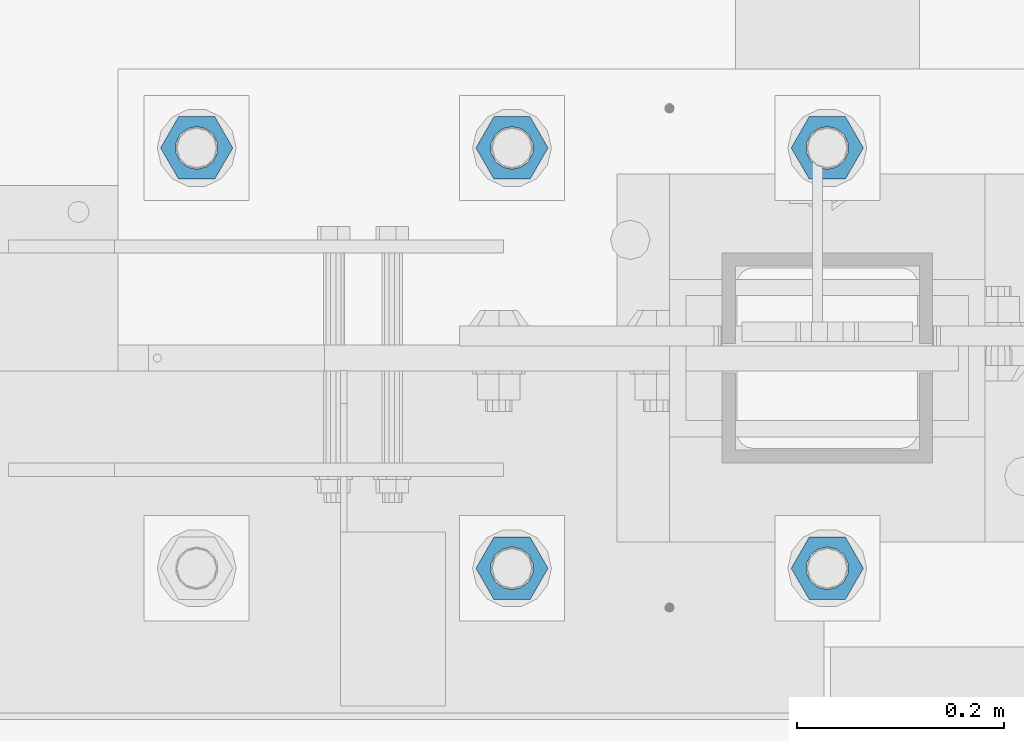
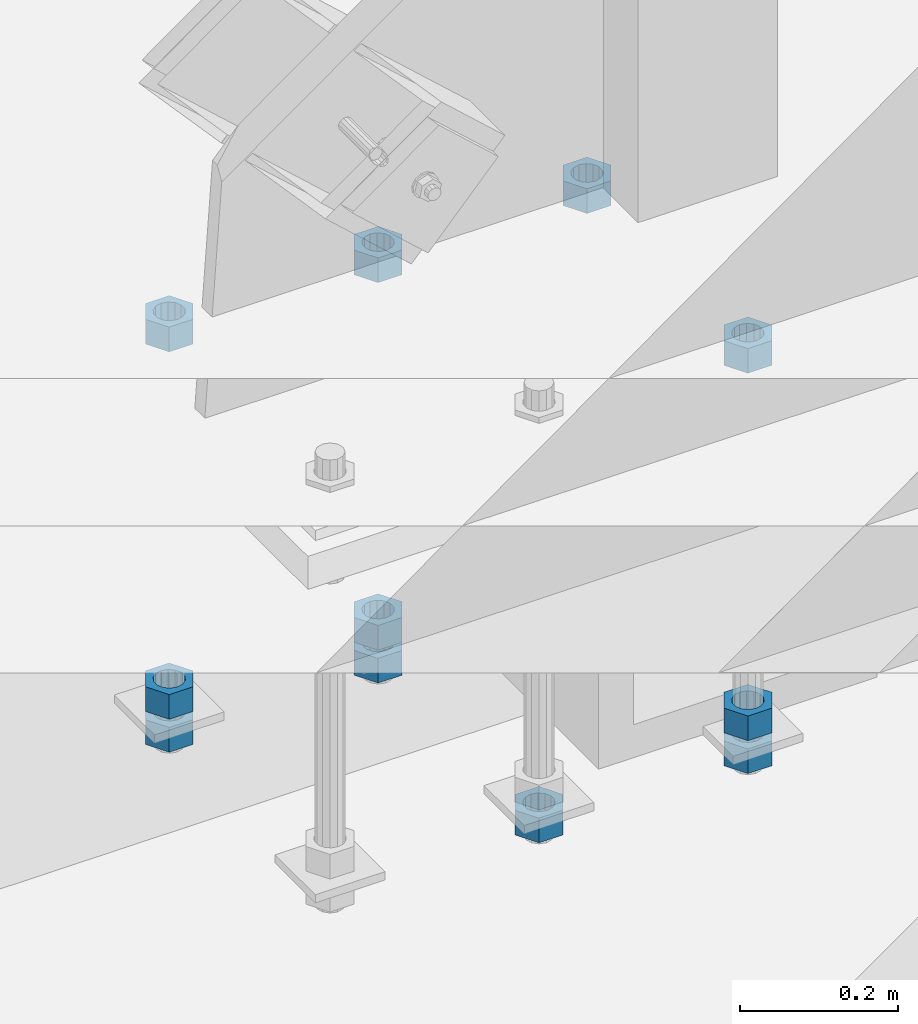
# One storey, part 982 of 1763: 11 columns, 1 element without a shape of its own.
"""IFC2X3 building model written with IfcOpenShell, lengths in millimetres."""

import ifcopenshell
import ifcopenshell.guid

model = None  # the IFC model being written
_history = None  # IfcOwnerHistory: only IFC2X3 demands one
_inside = {}  # id of a spatial element -> (the spatial element, [elements in it])
_under = {}  # id of a project, library or spatial element -> (it, [spatial elements below it])
_declared = {}  # id of a project -> (the project, [libraries it declares])
_typed = {}  # id of a type object -> (the type object, [elements of that type])
_made_of = {}  # id of a material, layer set ... -> (it, [elements and type objects made of it])


def new_model(schema):
    """Start an empty IFC model of exactly this schema.

    Asked for "IFC4X3", IfcOpenShell would pick the latest addendum, in which some entities
    have other attributes; the version numbers below select the first issue.
    IFC2X3 requires an IfcOwnerHistory on every rooted entity: one is made here for all.
    """
    global model, _history
    if schema == "IFC4X3":
        model = ifcopenshell.file(schema_version=(4, 3, 0, 0))
    else:
        model = ifcopenshell.file(schema=schema)
    _inside.clear()
    _under.clear()
    _declared.clear()
    _typed.clear()
    _made_of.clear()
    _history = None
    if model.schema == "IFC2X3":
        org = make("IfcOrganization", Name="unknown")
        user = make(
            "IfcPersonAndOrganization",
            ThePerson=make("IfcPerson", FamilyName="unknown"),
            TheOrganization=org,
        )
        app = make(
            "IfcApplication",
            ApplicationDeveloper=org,
            Version="unknown",
            ApplicationFullName="unknown",
            ApplicationIdentifier="unknown",
        )
        _history = make(
            "IfcOwnerHistory",
            OwningUser=user,
            OwningApplication=app,
            ChangeAction="ADDED",
            CreationDate=0,
        )
    return model


def make(cls, **values):
    """One entity of the class cls with the attributes given. An attribute that is None is left unset."""
    return model.create_entity(
        cls, **{name: value for name, value in values.items() if value is not None}
    )


def rooted(cls, **values):
    """An entity with a GlobalId (a new one), such as an element, a storey or a relation."""
    return make(cls, GlobalId=ifcopenshell.guid.new(), OwnerHistory=_history, **values)


def si_unit(unit_type, name, prefix=None):
    """IfcSIUnit, for example si_unit("LENGTHUNIT", "METRE", prefix="MILLI")."""
    return make("IfcSIUnit", UnitType=unit_type, Prefix=prefix, Name=name)


def assignment(units):
    """IfcUnitAssignment: the units of a project."""
    return None if units is None else make("IfcUnitAssignment", Units=units)


def point(xyz):
    """IfcCartesianPoint."""
    return None if xyz is None else make("IfcCartesianPoint", Coordinates=xyz)


def direction(xyz):
    """IfcDirection."""
    return None if xyz is None else make("IfcDirection", DirectionRatios=xyz)


def frame(location, z_axis=None, x_axis=None):
    """IfcAxis2Placement3D, a coordinate frame: its origin and axes. An axis left out is left unset."""
    return make(
        "IfcAxis2Placement3D",
        Location=point(location),
        Axis=direction(z_axis),
        RefDirection=direction(x_axis),
    )


def origin_with_axes():
    """The frame at (0, 0, 0) with the z axis (0, 0, 1) and the x axis (1, 0, 0) written out."""
    return frame((0.0, 0.0, 0.0), z_axis=(0.0, 0.0, 1.0), x_axis=(1.0, 0.0, 0.0))


def place(relative_to, where):
    """IfcLocalPlacement: puts the frame where relative to a parent placement (None: the world)."""
    return make(
        "IfcLocalPlacement", PlacementRelTo=relative_to, RelativePlacement=where
    )


def context(
    kind, dimensions, precision=None, world=None, true_north=None, identifier=None
):
    """IfcGeometricRepresentationContext, for example the 3D "Model" context."""
    return make(
        "IfcGeometricRepresentationContext",
        ContextIdentifier=identifier,
        ContextType=kind,
        CoordinateSpaceDimension=dimensions,
        Precision=precision,
        WorldCoordinateSystem=world,
        TrueNorth=true_north,
    )


def subcontext(parent, identifier, kind, view, scale=None):
    """IfcGeometricRepresentationSubContext, for example "Body" below "Model"."""
    return make(
        "IfcGeometricRepresentationSubContext",
        ContextIdentifier=identifier,
        ContextType=kind,
        ParentContext=parent,
        TargetScale=scale,
        TargetView=view,
    )


def project(units=None, contexts=None):
    """IfcProject with its units and contexts."""
    return rooted(
        "IfcProject",
        Name="project",
        RepresentationContexts=contexts,
        UnitsInContext=assignment(units),
    )


def spatial(cls, under=None, at=None, **own):
    """A site, building, storey or space (cls), placed at a placement, below another one or the project."""
    s = rooted(cls, ObjectPlacement=at, **own)
    if under is not None:
        _under.setdefault(under.id(), (under, []))[1].append(s)
    return s


def faces_of(points, faces, orient=None, outer=None):
    """IfcFace entities. A face is a list of loops; a loop is a list of indices into points, from 0.

    orient and outer hold one flag for each loop. By default every Orientation is true, the
    first loop of a face is its IfcFaceOuterBound and the others are IfcFaceBound.
    """
    made = []
    for i, loops in enumerate(faces):
        bounds = []
        for j, loop in enumerate(loops):
            is_outer = j == 0 if outer is None else outer[i][j]
            bounds.append(
                make(
                    "IfcFaceOuterBound" if is_outer else "IfcFaceBound",
                    Bound=make("IfcPolyLoop", Polygon=[points[k] for k in loop]),
                    Orientation=True if orient is None else orient[i][j],
                )
            )
        made.append(make("IfcFace", Bounds=bounds))
    return made


def faceted_brep(points, faces, orient=None, outer=None, voids=None):
    """IfcFacetedBrep: a solid bounded by flat faces; with voids (closed shells), ...WithVoids."""
    shared = [point(p) for p in points]
    hull = make("IfcClosedShell", CfsFaces=faces_of(shared, faces, orient, outer))
    if voids is None:
        return make("IfcFacetedBrep", Outer=hull)
    return make(
        "IfcFacetedBrepWithVoids",
        Outer=hull,
        Voids=[
            make(cls, CfsFaces=faces_of(shared, fs, o, b)) for cls, fs, o, b in voids
        ],
    )


def shape(context_of_items, identifier, shape_type, items):
    """IfcShapeRepresentation: the items that make up one representation, for example the "Body"."""
    return make(
        "IfcShapeRepresentation",
        ContextOfItems=context_of_items,
        RepresentationIdentifier=identifier,
        RepresentationType=shape_type,
        Items=items,
    )


def material(Name=None, Category=None):
    """IfcMaterial."""
    return make("IfcMaterial", Name=Name, Category=Category)


def made_of(thing, what):
    """Note that an element or type object is made of a material, layer set ...; save() writes the relation."""
    if what is not None:
        _made_of.setdefault(what.id(), (what, []))[1].append(thing)
    return thing


def type_object(cls, material=None, **own):
    """A type object (cls), such as IfcWallType, which elements share."""
    return made_of(rooted(cls, **own), material)


def element(
    cls,
    number,
    at=None,
    inside=None,
    cuts=None,
    type_object=None,
    material=None,
    context=None,
    identifier="Body",
    shape_type=None,
    held_by="IfcProductDefinitionShape",
    body=None,
    shapes=None,
    **own,
):
    """One element of the class cls, such as IfcWall. Its Tag is "e" and its number.

    at: its placement. inside: the storey or other place that contains it. cuts: it is an
    opening in that element (IfcRelVoidsElement). A single representation is given by context,
    identifier, shape_type and body (its items); several are given by shapes. held_by: the class
    of the entity that holds the representations. save() writes the other relations.
    """
    e = rooted(cls, Tag="e%d" % number, ObjectPlacement=at, **own)
    if body is not None:
        shapes = [shape(context, identifier, shape_type, body)]
    if shapes is not None:
        e.Representation = make(held_by, Representations=shapes)
    if inside is not None:
        _inside.setdefault(inside.id(), (inside, []))[1].append(e)
    if cuts is not None:
        rooted(
            "IfcRelVoidsElement", RelatingBuildingElement=cuts, RelatedOpeningElement=e
        )
    if type_object is not None:
        _typed.setdefault(type_object.id(), (type_object, []))[1].append(e)
    return made_of(e, material)


def aggregate(whole, parts):
    """IfcRelAggregates: a whole, such as a stair, and the parts it consists of."""
    return rooted("IfcRelAggregates", RelatingObject=whole, RelatedObjects=parts)


def save(model, path):
    """Write the relations noted so far, then the file.

    IfcRelAggregates (storeys below a building ...), IfcRelContainedInSpatialStructure (elements
    in a storey), IfcRelDefinesByType, IfcRelAssociatesMaterial and IfcRelDeclares: one each for
    every whole, place, type object, material and project.
    """
    for whole, parts in _under.values():
        aggregate(whole, parts)
    for where, things in _inside.values():
        rooted(
            "IfcRelContainedInSpatialStructure",
            RelatedElements=things,
            RelatingStructure=where,
        )
    for kind, things in _typed.values():
        rooted("IfcRelDefinesByType", RelatedObjects=things, RelatingType=kind)
    for what, things in _made_of.values():
        rooted("IfcRelAssociatesMaterial", RelatedObjects=things, RelatingMaterial=what)
    for by, libraries in _declared.values():
        rooted("IfcRelDeclares", RelatingContext=by, RelatedDefinitions=libraries)
    model.write(path)


model = new_model("IFC2X3")

# Units and contexts
model_context = context("Model", 3, precision=1e-05, world=origin_with_axes())
body_context = subcontext(model_context, "Body", "Model", "MODEL_VIEW")
ifc_project = project(units=[si_unit("LENGTHUNIT", "METRE", prefix="MILLI"), si_unit("AREAUNIT", "SQUARE_METRE"), si_unit("VOLUMEUNIT", "CUBIC_METRE"), si_unit("MASSUNIT", "GRAM", prefix="KILO"), si_unit("TIMEUNIT", "SECOND"), si_unit("PLANEANGLEUNIT", "RADIAN"), si_unit("SOLIDANGLEUNIT", "STERADIAN"), si_unit("THERMODYNAMICTEMPERATUREUNIT", "DEGREE_CELSIUS"), si_unit("LUMINOUSINTENSITYUNIT", "LUMEN")], contexts=[model_context])

# Site, building, storey
site_placement = place(None, origin_with_axes())
site = spatial("IfcSite", under=ifc_project, at=site_placement, CompositionType="ELEMENT")
building_placement = place(site_placement, origin_with_axes())
building = spatial("IfcBuilding", under=site, at=building_placement, Name="Undefined", CompositionType="ELEMENT")
storey_placement = place(building_placement, origin_with_axes())
storey = spatial("IfcBuildingStorey", under=building, at=storey_placement, Name="Undefined", CompositionType="ELEMENT", Elevation=0.0)

# Assembly, columns
assembly_placement = place(storey_placement, origin_with_axes())
assembly = element("IfcElementAssembly", 1, at=assembly_placement, inside=storey, Name="TEMPLATE", AssemblyPlace="NOTDEFINED", PredefinedType="RIGID_FRAME")
ifc_material = material(Name="STEEL/A563")
column_type = type_object("IfcColumnType", Name="1-1/2_HEAVY_HEX_NUT", PredefinedType="NOTDEFINED")
column_1_placement = place(assembly_placement, frame((-72795.8372736984, -13919.2, 4572.0), z_axis=(0.0, -1.0, 0.0), x_axis=(0.0, 0.0, -1.0)))
column_1 = element("IfcColumn", 2, at=column_1_placement, type_object=column_type, material=ifc_material, Name="NUT", ObjectType="1-1/2_HEAVY_HEX_NUT", context=body_context, shape_type="Brep", body=[
    faceted_brep([(0.0, -34.9199981689453, 0.0), (0.0, -17.4599990844727, -30.25), (38.1000000000004, -17.4599990844727, -30.25), (38.1000000000004, -34.9199981689453, 0.0), (0.0, 17.4599990844727, -30.25), (38.1000000000004, 17.4599990844727, -30.25), (0.0, 34.9199981689453, 0.0), (38.1000000000004, 34.9199981689453, 0.0), (0.0, 17.4599990844727, 30.25), (38.1000000000004, 17.4599990844727, 30.25), (0.0, -17.4599990844727, 30.25), (38.1000000000004, -17.4599990844727, 30.25), (0.0, 0.0, 20.6399993896484), (0.0, 8.95536011056538, 18.5959968835978), (38.1000000000004, 8.95536011056538, 18.5959968835978), (38.1000000000004, 0.0, 20.6399993896484), (0.0, 16.1370013209453, 12.8688291298167), (38.1000000000004, 16.1370013209453, 12.8688291298167), (0.0, 20.1225115123816, 4.59283194104137), (38.1000000000004, 20.1225115123816, 4.59283194104137), (0.0, 20.1225115123816, -4.59283194104319), (38.1000000000004, 20.1225115123816, -4.59283194104319), (0.0, 16.1370013209453, -12.8688291298167), (38.1000000000004, 16.1370013209453, -12.8688291298167), (0.0, 8.95536011056538, -18.5959968835978), (38.1000000000004, 8.95536011056538, -18.5959968835978), (0.0, 0.0, -20.6399993896484), (38.1000000000004, 0.0, -20.6399993896484), (0.0, -8.95536011056538, -18.5959968835978), (38.1000000000004, -8.95536011056538, -18.5959968835978), (0.0, -16.1370013209453, -12.8688291298167), (38.1000000000004, -16.1370013209453, -12.8688291298167), (0.0, -20.1225115123816, -4.59283194104137), (38.1000000000004, -20.1225115123816, -4.59283194104137), (0.0, -20.1225115123816, 4.59283194104319), (38.1000000000004, -20.1225115123816, 4.59283194104319), (0.0, -16.1370013209453, 12.8688291298167), (38.1000000000004, -16.1370013209453, 12.8688291298167), (0.0, -8.95536011056538, 18.5959968835978), (38.1000000000004, -8.95536011056538, 18.5959968835978)], [[[0, 1, 2, 3]], [[1, 4, 5, 2]], [[4, 6, 7, 5]], [[6, 8, 9, 7]], [[8, 10, 11, 9]], [[10, 0, 3, 11]], [[12, 13, 14, 15]], [[13, 16, 17, 14]], [[16, 18, 19, 17]], [[18, 20, 21, 19]], [[20, 22, 23, 21]], [[22, 24, 25, 23]], [[24, 26, 27, 25]], [[26, 28, 29, 27]], [[28, 30, 31, 29]], [[30, 32, 33, 31]], [[32, 34, 35, 33]], [[34, 36, 37, 35]], [[36, 38, 39, 37]], [[38, 12, 15, 39]], [[5, 7, 9, 11, 3, 2], [17, 19, 21, 23, 25, 27, 29, 31, 33, 35, 37, 39, 15, 14]], [[10, 8, 6, 4, 1, 0], [38, 36, 34, 32, 30, 28, 26, 24, 22, 20, 18, 16, 13, 12]]]),
])
column_2_placement = place(assembly_placement, frame((-72491.0372736984, -13919.2, 5189.5375), z_axis=(0.0, 1.0, 0.0), x_axis=(0.0, 0.0, -1.0)))
column_2 = element("IfcColumn", 3, at=column_2_placement, type_object=column_type, material=ifc_material, Name="NUT", ObjectType="1-1/2_HEAVY_HEX_NUT", context=body_context, shape_type="Brep", body=[
    faceted_brep([(0.0, -34.9199981689453, 0.0), (0.0, -17.4599990844727, -30.25), (38.1000000000004, -17.4599990844727, -30.25), (38.1000000000004, -34.9199981689453, 0.0), (0.0, 17.4599990844727, -30.25), (38.1000000000004, 17.4599990844727, -30.25), (0.0, 34.9199981689453, 0.0), (38.1000000000004, 34.9199981689453, 0.0), (0.0, 17.4599990844727, 30.25), (38.1000000000004, 17.4599990844727, 30.25), (0.0, -17.4599990844727, 30.25), (38.1000000000004, -17.4599990844727, 30.25), (0.0, 0.0, 20.6399993896484), (0.0, 8.95536011056538, 18.5959968835978), (38.1000000000004, 8.95536011056538, 18.5959968835978), (38.1000000000004, 0.0, 20.6399993896484), (0.0, 16.1370013209453, 12.8688291298167), (38.1000000000004, 16.1370013209453, 12.8688291298167), (0.0, 20.1225115123816, 4.59283194104137), (38.1000000000004, 20.1225115123816, 4.59283194104137), (0.0, 20.1225115123816, -4.59283194104319), (38.1000000000004, 20.1225115123816, -4.59283194104319), (0.0, 16.1370013209453, -12.8688291298167), (38.1000000000004, 16.1370013209453, -12.8688291298167), (0.0, 8.95536011056538, -18.5959968835978), (38.1000000000004, 8.95536011056538, -18.5959968835978), (0.0, 0.0, -20.6399993896484), (38.1000000000004, 0.0, -20.6399993896484), (0.0, -8.95536011056538, -18.5959968835978), (38.1000000000004, -8.95536011056538, -18.5959968835978), (0.0, -16.1370013209453, -12.8688291298167), (38.1000000000004, -16.1370013209453, -12.8688291298167), (0.0, -20.1225115123816, -4.59283194104137), (38.1000000000004, -20.1225115123816, -4.59283194104137), (0.0, -20.1225115123816, 4.59283194104319), (38.1000000000004, -20.1225115123816, 4.59283194104319), (0.0, -16.1370013209453, 12.8688291298167), (38.1000000000004, -16.1370013209453, 12.8688291298167), (0.0, -8.95536011056538, 18.5959968835978), (38.1000000000004, -8.95536011056538, 18.5959968835978)], [[[0, 1, 2, 3]], [[1, 4, 5, 2]], [[4, 6, 7, 5]], [[6, 8, 9, 7]], [[8, 10, 11, 9]], [[10, 0, 3, 11]], [[12, 13, 14, 15]], [[13, 16, 17, 14]], [[16, 18, 19, 17]], [[18, 20, 21, 19]], [[20, 22, 23, 21]], [[22, 24, 25, 23]], [[24, 26, 27, 25]], [[26, 28, 29, 27]], [[28, 30, 31, 29]], [[30, 32, 33, 31]], [[32, 34, 35, 33]], [[34, 36, 37, 35]], [[36, 38, 39, 37]], [[38, 12, 15, 39]], [[5, 7, 9, 11, 3, 2], [17, 19, 21, 23, 25, 27, 29, 31, 33, 35, 37, 39, 15, 14]], [[10, 8, 6, 4, 1, 0], [38, 36, 34, 32, 30, 28, 26, 24, 22, 20, 18, 16, 13, 12]]]),
])
column_3_placement = place(assembly_placement, frame((-72491.0372736984, -13919.2, 4622.8), z_axis=(0.0, 1.0, 0.0), x_axis=(0.0, 0.0, -1.0)))
column_3 = element("IfcColumn", 4, at=column_3_placement, type_object=column_type, material=ifc_material, Name="NUT", ObjectType="1-1/2_HEAVY_HEX_NUT", context=body_context, shape_type="Brep", body=[
    faceted_brep([(0.0, -34.9199981689453, 0.0), (0.0, -17.4599990844727, -30.25), (38.1000000000004, -17.4599990844727, -30.25), (38.1000000000004, -34.9199981689453, 0.0), (0.0, 17.4599990844727, -30.25), (38.1000000000004, 17.4599990844727, -30.25), (0.0, 34.9199981689453, 0.0), (38.1000000000004, 34.9199981689453, 0.0), (0.0, 17.4599990844727, 30.25), (38.1000000000004, 17.4599990844727, 30.25), (0.0, -17.4599990844727, 30.25), (38.1000000000004, -17.4599990844727, 30.25), (0.0, 0.0, 20.6399993896484), (0.0, 8.95536011056538, 18.5959968835978), (38.1000000000004, 8.95536011056538, 18.5959968835978), (38.1000000000004, 0.0, 20.6399993896484), (0.0, 16.1370013209453, 12.8688291298167), (38.1000000000004, 16.1370013209453, 12.8688291298167), (0.0, 20.1225115123816, 4.59283194104137), (38.1000000000004, 20.1225115123816, 4.59283194104137), (0.0, 20.1225115123816, -4.59283194104319), (38.1000000000004, 20.1225115123816, -4.59283194104319), (0.0, 16.1370013209453, -12.8688291298167), (38.1000000000004, 16.1370013209453, -12.8688291298167), (0.0, 8.95536011056538, -18.5959968835978), (38.1000000000004, 8.95536011056538, -18.5959968835978), (0.0, 0.0, -20.6399993896484), (38.1000000000004, 0.0, -20.6399993896484), (0.0, -8.95536011056538, -18.5959968835978), (38.1000000000004, -8.95536011056538, -18.5959968835978), (0.0, -16.1370013209453, -12.8688291298167), (38.1000000000004, -16.1370013209453, -12.8688291298167), (0.0, -20.1225115123816, -4.59283194104137), (38.1000000000004, -20.1225115123816, -4.59283194104137), (0.0, -20.1225115123816, 4.59283194104319), (38.1000000000004, -20.1225115123816, 4.59283194104319), (0.0, -16.1370013209453, 12.8688291298167), (38.1000000000004, -16.1370013209453, 12.8688291298167), (0.0, -8.95536011056538, 18.5959968835978), (38.1000000000004, -8.95536011056538, 18.5959968835978)], [[[0, 1, 2, 3]], [[1, 4, 5, 2]], [[4, 6, 7, 5]], [[6, 8, 9, 7]], [[8, 10, 11, 9]], [[10, 0, 3, 11]], [[12, 13, 14, 15]], [[13, 16, 17, 14]], [[16, 18, 19, 17]], [[18, 20, 21, 19]], [[20, 22, 23, 21]], [[22, 24, 25, 23]], [[24, 26, 27, 25]], [[26, 28, 29, 27]], [[28, 30, 31, 29]], [[30, 32, 33, 31]], [[32, 34, 35, 33]], [[34, 36, 37, 35]], [[36, 38, 39, 37]], [[38, 12, 15, 39]], [[5, 7, 9, 11, 3, 2], [17, 19, 21, 23, 25, 27, 29, 31, 33, 35, 37, 39, 15, 14]], [[10, 8, 6, 4, 1, 0], [38, 36, 34, 32, 30, 28, 26, 24, 22, 20, 18, 16, 13, 12]]]),
])
column_4_placement = place(assembly_placement, frame((-72491.0372736984, -13919.2, 4572.0), z_axis=(0.0, 1.0, 0.0), x_axis=(0.0, 0.0, -1.0)))
column_4 = element("IfcColumn", 5, at=column_4_placement, type_object=column_type, material=ifc_material, Name="NUT", ObjectType="1-1/2_HEAVY_HEX_NUT", context=body_context, shape_type="Brep", body=[
    faceted_brep([(0.0, -34.9199981689453, 0.0), (0.0, -17.4599990844727, -30.25), (38.1000000000004, -17.4599990844727, -30.25), (38.1000000000004, -34.9199981689453, 0.0), (0.0, 17.4599990844727, -30.25), (38.1000000000004, 17.4599990844727, -30.25), (0.0, 34.9199981689453, 0.0), (38.1000000000004, 34.9199981689453, 0.0), (0.0, 17.4599990844727, 30.25), (38.1000000000004, 17.4599990844727, 30.25), (0.0, -17.4599990844727, 30.25), (38.1000000000004, -17.4599990844727, 30.25), (0.0, 0.0, 20.6399993896484), (0.0, 8.95536011056538, 18.5959968835978), (38.1000000000004, 8.95536011056538, 18.5959968835978), (38.1000000000004, 0.0, 20.6399993896484), (0.0, 16.1370013209453, 12.8688291298167), (38.1000000000004, 16.1370013209453, 12.8688291298167), (0.0, 20.1225115123816, 4.59283194104137), (38.1000000000004, 20.1225115123816, 4.59283194104137), (0.0, 20.1225115123816, -4.59283194104319), (38.1000000000004, 20.1225115123816, -4.59283194104319), (0.0, 16.1370013209453, -12.8688291298167), (38.1000000000004, 16.1370013209453, -12.8688291298167), (0.0, 8.95536011056538, -18.5959968835978), (38.1000000000004, 8.95536011056538, -18.5959968835978), (0.0, 0.0, -20.6399993896484), (38.1000000000004, 0.0, -20.6399993896484), (0.0, -8.95536011056538, -18.5959968835978), (38.1000000000004, -8.95536011056538, -18.5959968835978), (0.0, -16.1370013209453, -12.8688291298167), (38.1000000000004, -16.1370013209453, -12.8688291298167), (0.0, -20.1225115123816, -4.59283194104137), (38.1000000000004, -20.1225115123816, -4.59283194104137), (0.0, -20.1225115123816, 4.59283194104319), (38.1000000000004, -20.1225115123816, 4.59283194104319), (0.0, -16.1370013209453, 12.8688291298167), (38.1000000000004, -16.1370013209453, 12.8688291298167), (0.0, -8.95536011056538, 18.5959968835978), (38.1000000000004, -8.95536011056538, 18.5959968835978)], [[[0, 1, 2, 3]], [[1, 4, 5, 2]], [[4, 6, 7, 5]], [[6, 8, 9, 7]], [[8, 10, 11, 9]], [[10, 0, 3, 11]], [[12, 13, 14, 15]], [[13, 16, 17, 14]], [[16, 18, 19, 17]], [[18, 20, 21, 19]], [[20, 22, 23, 21]], [[22, 24, 25, 23]], [[24, 26, 27, 25]], [[26, 28, 29, 27]], [[28, 30, 31, 29]], [[30, 32, 33, 31]], [[32, 34, 35, 33]], [[34, 36, 37, 35]], [[36, 38, 39, 37]], [[38, 12, 15, 39]], [[5, 7, 9, 11, 3, 2], [17, 19, 21, 23, 25, 27, 29, 31, 33, 35, 37, 39, 15, 14]], [[10, 8, 6, 4, 1, 0], [38, 36, 34, 32, 30, 28, 26, 24, 22, 20, 18, 16, 13, 12]]]),
])
column_5_placement = place(assembly_placement, frame((-73100.6372736984, -13512.8, 5189.5375), z_axis=(0.0, -1.0, 0.0), x_axis=(0.0, 0.0, -1.0)))
column_5 = element("IfcColumn", 6, at=column_5_placement, type_object=column_type, material=ifc_material, Name="NUT", ObjectType="1-1/2_HEAVY_HEX_NUT", context=body_context, shape_type="Brep", body=[
    faceted_brep([(0.0, -34.9199981689453, 0.0), (0.0, -17.4599990844727, -30.25), (38.1000000000004, -17.4599990844727, -30.25), (38.1000000000004, -34.9199981689453, 0.0), (0.0, 17.4599990844727, -30.25), (38.1000000000004, 17.4599990844727, -30.25), (0.0, 34.9199981689453, 0.0), (38.1000000000004, 34.9199981689453, 0.0), (0.0, 17.4599990844727, 30.25), (38.1000000000004, 17.4599990844727, 30.25), (0.0, -17.4599990844727, 30.25), (38.1000000000004, -17.4599990844727, 30.25), (0.0, 0.0, 20.6399993896484), (0.0, 8.95536011056538, 18.5959968835978), (38.1000000000004, 8.95536011056538, 18.5959968835978), (38.1000000000004, 0.0, 20.6399993896484), (0.0, 16.1370013209453, 12.8688291298167), (38.1000000000004, 16.1370013209453, 12.8688291298167), (0.0, 20.1225115123816, 4.59283194104137), (38.1000000000004, 20.1225115123816, 4.59283194104137), (0.0, 20.1225115123816, -4.59283194104319), (38.1000000000004, 20.1225115123816, -4.59283194104319), (0.0, 16.1370013209453, -12.8688291298167), (38.1000000000004, 16.1370013209453, -12.8688291298167), (0.0, 8.95536011056538, -18.5959968835978), (38.1000000000004, 8.95536011056538, -18.5959968835978), (0.0, 0.0, -20.6399993896484), (38.1000000000004, 0.0, -20.6399993896484), (0.0, -8.95536011056538, -18.5959968835978), (38.1000000000004, -8.95536011056538, -18.5959968835978), (0.0, -16.1370013209453, -12.8688291298167), (38.1000000000004, -16.1370013209453, -12.8688291298167), (0.0, -20.1225115123816, -4.59283194104137), (38.1000000000004, -20.1225115123816, -4.59283194104137), (0.0, -20.1225115123816, 4.59283194104319), (38.1000000000004, -20.1225115123816, 4.59283194104319), (0.0, -16.1370013209453, 12.8688291298167), (38.1000000000004, -16.1370013209453, 12.8688291298167), (0.0, -8.95536011056538, 18.5959968835978), (38.1000000000004, -8.95536011056538, 18.5959968835978)], [[[0, 1, 2, 3]], [[1, 4, 5, 2]], [[4, 6, 7, 5]], [[6, 8, 9, 7]], [[8, 10, 11, 9]], [[10, 0, 3, 11]], [[12, 13, 14, 15]], [[13, 16, 17, 14]], [[16, 18, 19, 17]], [[18, 20, 21, 19]], [[20, 22, 23, 21]], [[22, 24, 25, 23]], [[24, 26, 27, 25]], [[26, 28, 29, 27]], [[28, 30, 31, 29]], [[30, 32, 33, 31]], [[32, 34, 35, 33]], [[34, 36, 37, 35]], [[36, 38, 39, 37]], [[38, 12, 15, 39]], [[5, 7, 9, 11, 3, 2], [17, 19, 21, 23, 25, 27, 29, 31, 33, 35, 37, 39, 15, 14]], [[10, 8, 6, 4, 1, 0], [38, 36, 34, 32, 30, 28, 26, 24, 22, 20, 18, 16, 13, 12]]]),
])
column_6_placement = place(assembly_placement, frame((-73100.6372736984, -13512.8, 4622.8), z_axis=(0.0, -1.0, 0.0), x_axis=(0.0, 0.0, -1.0)))
column_6 = element("IfcColumn", 7, at=column_6_placement, type_object=column_type, material=ifc_material, Name="NUT", ObjectType="1-1/2_HEAVY_HEX_NUT", context=body_context, shape_type="Brep", body=[
    faceted_brep([(0.0, -34.9199981689453, 0.0), (0.0, -17.4599990844727, -30.25), (38.1000000000004, -17.4599990844727, -30.25), (38.1000000000004, -34.9199981689453, 0.0), (0.0, 17.4599990844727, -30.25), (38.1000000000004, 17.4599990844727, -30.25), (0.0, 34.9199981689453, 0.0), (38.1000000000004, 34.9199981689453, 0.0), (0.0, 17.4599990844727, 30.25), (38.1000000000004, 17.4599990844727, 30.25), (0.0, -17.4599990844727, 30.25), (38.1000000000004, -17.4599990844727, 30.25), (0.0, 0.0, 20.6399993896484), (0.0, 8.95536011056538, 18.5959968835978), (38.1000000000004, 8.95536011056538, 18.5959968835978), (38.1000000000004, 0.0, 20.6399993896484), (0.0, 16.1370013209453, 12.8688291298167), (38.1000000000004, 16.1370013209453, 12.8688291298167), (0.0, 20.1225115123816, 4.59283194104137), (38.1000000000004, 20.1225115123816, 4.59283194104137), (0.0, 20.1225115123816, -4.59283194104319), (38.1000000000004, 20.1225115123816, -4.59283194104319), (0.0, 16.1370013209453, -12.8688291298167), (38.1000000000004, 16.1370013209453, -12.8688291298167), (0.0, 8.95536011056538, -18.5959968835978), (38.1000000000004, 8.95536011056538, -18.5959968835978), (0.0, 0.0, -20.6399993896484), (38.1000000000004, 0.0, -20.6399993896484), (0.0, -8.95536011056538, -18.5959968835978), (38.1000000000004, -8.95536011056538, -18.5959968835978), (0.0, -16.1370013209453, -12.8688291298167), (38.1000000000004, -16.1370013209453, -12.8688291298167), (0.0, -20.1225115123816, -4.59283194104137), (38.1000000000004, -20.1225115123816, -4.59283194104137), (0.0, -20.1225115123816, 4.59283194104319), (38.1000000000004, -20.1225115123816, 4.59283194104319), (0.0, -16.1370013209453, 12.8688291298167), (38.1000000000004, -16.1370013209453, 12.8688291298167), (0.0, -8.95536011056538, 18.5959968835978), (38.1000000000004, -8.95536011056538, 18.5959968835978)], [[[0, 1, 2, 3]], [[1, 4, 5, 2]], [[4, 6, 7, 5]], [[6, 8, 9, 7]], [[8, 10, 11, 9]], [[10, 0, 3, 11]], [[12, 13, 14, 15]], [[13, 16, 17, 14]], [[16, 18, 19, 17]], [[18, 20, 21, 19]], [[20, 22, 23, 21]], [[22, 24, 25, 23]], [[24, 26, 27, 25]], [[26, 28, 29, 27]], [[28, 30, 31, 29]], [[30, 32, 33, 31]], [[32, 34, 35, 33]], [[34, 36, 37, 35]], [[36, 38, 39, 37]], [[38, 12, 15, 39]], [[5, 7, 9, 11, 3, 2], [17, 19, 21, 23, 25, 27, 29, 31, 33, 35, 37, 39, 15, 14]], [[10, 8, 6, 4, 1, 0], [38, 36, 34, 32, 30, 28, 26, 24, 22, 20, 18, 16, 13, 12]]]),
])
column_7_placement = place(assembly_placement, frame((-73100.6372736984, -13512.8, 4572.0), z_axis=(0.0, -1.0, 0.0), x_axis=(0.0, 0.0, -1.0)))
column_7 = element("IfcColumn", 8, at=column_7_placement, type_object=column_type, material=ifc_material, Name="NUT", ObjectType="1-1/2_HEAVY_HEX_NUT", context=body_context, shape_type="Brep", body=[
    faceted_brep([(0.0, -34.9199981689453, 0.0), (0.0, -17.4599990844727, -30.25), (38.1000000000004, -17.4599990844727, -30.25), (38.1000000000004, -34.9199981689453, 0.0), (0.0, 17.4599990844727, -30.25), (38.1000000000004, 17.4599990844727, -30.25), (0.0, 34.9199981689453, 0.0), (38.1000000000004, 34.9199981689453, 0.0), (0.0, 17.4599990844727, 30.25), (38.1000000000004, 17.4599990844727, 30.25), (0.0, -17.4599990844727, 30.25), (38.1000000000004, -17.4599990844727, 30.25), (0.0, 0.0, 20.6399993896484), (0.0, 8.95536011056538, 18.5959968835978), (38.1000000000004, 8.95536011056538, 18.5959968835978), (38.1000000000004, 0.0, 20.6399993896484), (0.0, 16.1370013209453, 12.8688291298167), (38.1000000000004, 16.1370013209453, 12.8688291298167), (0.0, 20.1225115123816, 4.59283194104137), (38.1000000000004, 20.1225115123816, 4.59283194104137), (0.0, 20.1225115123816, -4.59283194104319), (38.1000000000004, 20.1225115123816, -4.59283194104319), (0.0, 16.1370013209453, -12.8688291298167), (38.1000000000004, 16.1370013209453, -12.8688291298167), (0.0, 8.95536011056538, -18.5959968835978), (38.1000000000004, 8.95536011056538, -18.5959968835978), (0.0, 0.0, -20.6399993896484), (38.1000000000004, 0.0, -20.6399993896484), (0.0, -8.95536011056538, -18.5959968835978), (38.1000000000004, -8.95536011056538, -18.5959968835978), (0.0, -16.1370013209453, -12.8688291298167), (38.1000000000004, -16.1370013209453, -12.8688291298167), (0.0, -20.1225115123816, -4.59283194104137), (38.1000000000004, -20.1225115123816, -4.59283194104137), (0.0, -20.1225115123816, 4.59283194104319), (38.1000000000004, -20.1225115123816, 4.59283194104319), (0.0, -16.1370013209453, 12.8688291298167), (38.1000000000004, -16.1370013209453, 12.8688291298167), (0.0, -8.95536011056538, 18.5959968835978), (38.1000000000004, -8.95536011056538, 18.5959968835978)], [[[0, 1, 2, 3]], [[1, 4, 5, 2]], [[4, 6, 7, 5]], [[6, 8, 9, 7]], [[8, 10, 11, 9]], [[10, 0, 3, 11]], [[12, 13, 14, 15]], [[13, 16, 17, 14]], [[16, 18, 19, 17]], [[18, 20, 21, 19]], [[20, 22, 23, 21]], [[22, 24, 25, 23]], [[24, 26, 27, 25]], [[26, 28, 29, 27]], [[28, 30, 31, 29]], [[30, 32, 33, 31]], [[32, 34, 35, 33]], [[34, 36, 37, 35]], [[36, 38, 39, 37]], [[38, 12, 15, 39]], [[5, 7, 9, 11, 3, 2], [17, 19, 21, 23, 25, 27, 29, 31, 33, 35, 37, 39, 15, 14]], [[10, 8, 6, 4, 1, 0], [38, 36, 34, 32, 30, 28, 26, 24, 22, 20, 18, 16, 13, 12]]]),
])
column_8_placement = place(assembly_placement, frame((-72795.8372736984, -13512.8, 5189.5375), z_axis=(0.0, -1.0, 0.0), x_axis=(0.0, 0.0, -1.0)))
column_8 = element("IfcColumn", 9, at=column_8_placement, type_object=column_type, material=ifc_material, Name="NUT", ObjectType="1-1/2_HEAVY_HEX_NUT", context=body_context, shape_type="Brep", body=[
    faceted_brep([(0.0, -34.9199981689453, 0.0), (0.0, -17.4599990844727, -30.25), (38.1000000000004, -17.4599990844727, -30.25), (38.1000000000004, -34.9199981689453, 0.0), (0.0, 17.4599990844727, -30.25), (38.1000000000004, 17.4599990844727, -30.25), (0.0, 34.9199981689453, 0.0), (38.1000000000004, 34.9199981689453, 0.0), (0.0, 17.4599990844727, 30.25), (38.1000000000004, 17.4599990844727, 30.25), (0.0, -17.4599990844727, 30.25), (38.1000000000004, -17.4599990844727, 30.25), (0.0, 0.0, 20.6399993896484), (0.0, 8.95536011056538, 18.5959968835978), (38.1000000000004, 8.95536011056538, 18.5959968835978), (38.1000000000004, 0.0, 20.6399993896484), (0.0, 16.1370013209453, 12.8688291298167), (38.1000000000004, 16.1370013209453, 12.8688291298167), (0.0, 20.1225115123816, 4.59283194104137), (38.1000000000004, 20.1225115123816, 4.59283194104137), (0.0, 20.1225115123816, -4.59283194104319), (38.1000000000004, 20.1225115123816, -4.59283194104319), (0.0, 16.1370013209453, -12.8688291298167), (38.1000000000004, 16.1370013209453, -12.8688291298167), (0.0, 8.95536011056538, -18.5959968835978), (38.1000000000004, 8.95536011056538, -18.5959968835978), (0.0, 0.0, -20.6399993896484), (38.1000000000004, 0.0, -20.6399993896484), (0.0, -8.95536011056538, -18.5959968835978), (38.1000000000004, -8.95536011056538, -18.5959968835978), (0.0, -16.1370013209453, -12.8688291298167), (38.1000000000004, -16.1370013209453, -12.8688291298167), (0.0, -20.1225115123816, -4.59283194104137), (38.1000000000004, -20.1225115123816, -4.59283194104137), (0.0, -20.1225115123816, 4.59283194104319), (38.1000000000004, -20.1225115123816, 4.59283194104319), (0.0, -16.1370013209453, 12.8688291298167), (38.1000000000004, -16.1370013209453, 12.8688291298167), (0.0, -8.95536011056538, 18.5959968835978), (38.1000000000004, -8.95536011056538, 18.5959968835978)], [[[0, 1, 2, 3]], [[1, 4, 5, 2]], [[4, 6, 7, 5]], [[6, 8, 9, 7]], [[8, 10, 11, 9]], [[10, 0, 3, 11]], [[12, 13, 14, 15]], [[13, 16, 17, 14]], [[16, 18, 19, 17]], [[18, 20, 21, 19]], [[20, 22, 23, 21]], [[22, 24, 25, 23]], [[24, 26, 27, 25]], [[26, 28, 29, 27]], [[28, 30, 31, 29]], [[30, 32, 33, 31]], [[32, 34, 35, 33]], [[34, 36, 37, 35]], [[36, 38, 39, 37]], [[38, 12, 15, 39]], [[5, 7, 9, 11, 3, 2], [17, 19, 21, 23, 25, 27, 29, 31, 33, 35, 37, 39, 15, 14]], [[10, 8, 6, 4, 1, 0], [38, 36, 34, 32, 30, 28, 26, 24, 22, 20, 18, 16, 13, 12]]]),
])
column_9_placement = place(assembly_placement, frame((-72795.8372736984, -13512.8, 4622.8), z_axis=(0.0, -1.0, 0.0), x_axis=(0.0, 0.0, -1.0)))
column_9 = element("IfcColumn", 10, at=column_9_placement, type_object=column_type, material=ifc_material, Name="NUT", ObjectType="1-1/2_HEAVY_HEX_NUT", context=body_context, shape_type="Brep", body=[
    faceted_brep([(0.0, -34.9199981689453, 0.0), (0.0, -17.4599990844727, -30.25), (38.1000000000004, -17.4599990844727, -30.25), (38.1000000000004, -34.9199981689453, 0.0), (0.0, 17.4599990844727, -30.25), (38.1000000000004, 17.4599990844727, -30.25), (0.0, 34.9199981689453, 0.0), (38.1000000000004, 34.9199981689453, 0.0), (0.0, 17.4599990844727, 30.25), (38.1000000000004, 17.4599990844727, 30.25), (0.0, -17.4599990844727, 30.25), (38.1000000000004, -17.4599990844727, 30.25), (0.0, 0.0, 20.6399993896484), (0.0, 8.95536011056538, 18.5959968835978), (38.1000000000004, 8.95536011056538, 18.5959968835978), (38.1000000000004, 0.0, 20.6399993896484), (0.0, 16.1370013209453, 12.8688291298167), (38.1000000000004, 16.1370013209453, 12.8688291298167), (0.0, 20.1225115123816, 4.59283194104137), (38.1000000000004, 20.1225115123816, 4.59283194104137), (0.0, 20.1225115123816, -4.59283194104319), (38.1000000000004, 20.1225115123816, -4.59283194104319), (0.0, 16.1370013209453, -12.8688291298167), (38.1000000000004, 16.1370013209453, -12.8688291298167), (0.0, 8.95536011056538, -18.5959968835978), (38.1000000000004, 8.95536011056538, -18.5959968835978), (0.0, 0.0, -20.6399993896484), (38.1000000000004, 0.0, -20.6399993896484), (0.0, -8.95536011056538, -18.5959968835978), (38.1000000000004, -8.95536011056538, -18.5959968835978), (0.0, -16.1370013209453, -12.8688291298167), (38.1000000000004, -16.1370013209453, -12.8688291298167), (0.0, -20.1225115123816, -4.59283194104137), (38.1000000000004, -20.1225115123816, -4.59283194104137), (0.0, -20.1225115123816, 4.59283194104319), (38.1000000000004, -20.1225115123816, 4.59283194104319), (0.0, -16.1370013209453, 12.8688291298167), (38.1000000000004, -16.1370013209453, 12.8688291298167), (0.0, -8.95536011056538, 18.5959968835978), (38.1000000000004, -8.95536011056538, 18.5959968835978)], [[[0, 1, 2, 3]], [[1, 4, 5, 2]], [[4, 6, 7, 5]], [[6, 8, 9, 7]], [[8, 10, 11, 9]], [[10, 0, 3, 11]], [[12, 13, 14, 15]], [[13, 16, 17, 14]], [[16, 18, 19, 17]], [[18, 20, 21, 19]], [[20, 22, 23, 21]], [[22, 24, 25, 23]], [[24, 26, 27, 25]], [[26, 28, 29, 27]], [[28, 30, 31, 29]], [[30, 32, 33, 31]], [[32, 34, 35, 33]], [[34, 36, 37, 35]], [[36, 38, 39, 37]], [[38, 12, 15, 39]], [[5, 7, 9, 11, 3, 2], [17, 19, 21, 23, 25, 27, 29, 31, 33, 35, 37, 39, 15, 14]], [[10, 8, 6, 4, 1, 0], [38, 36, 34, 32, 30, 28, 26, 24, 22, 20, 18, 16, 13, 12]]]),
])
column_10_placement = place(assembly_placement, frame((-72795.8372736984, -13512.8, 4572.0), z_axis=(0.0, -1.0, 0.0), x_axis=(0.0, 0.0, -1.0)))
column_10 = element("IfcColumn", 11, at=column_10_placement, type_object=column_type, material=ifc_material, Name="NUT", ObjectType="1-1/2_HEAVY_HEX_NUT", context=body_context, shape_type="Brep", body=[
    faceted_brep([(0.0, -34.9199981689453, 0.0), (0.0, -17.4599990844727, -30.25), (38.1000000000004, -17.4599990844727, -30.25), (38.1000000000004, -34.9199981689453, 0.0), (0.0, 17.4599990844727, -30.25), (38.1000000000004, 17.4599990844727, -30.25), (0.0, 34.9199981689453, 0.0), (38.1000000000004, 34.9199981689453, 0.0), (0.0, 17.4599990844727, 30.25), (38.1000000000004, 17.4599990844727, 30.25), (0.0, -17.4599990844727, 30.25), (38.1000000000004, -17.4599990844727, 30.25), (0.0, 0.0, 20.6399993896484), (0.0, 8.95536011056538, 18.5959968835978), (38.1000000000004, 8.95536011056538, 18.5959968835978), (38.1000000000004, 0.0, 20.6399993896484), (0.0, 16.1370013209453, 12.8688291298167), (38.1000000000004, 16.1370013209453, 12.8688291298167), (0.0, 20.1225115123816, 4.59283194104137), (38.1000000000004, 20.1225115123816, 4.59283194104137), (0.0, 20.1225115123816, -4.59283194104319), (38.1000000000004, 20.1225115123816, -4.59283194104319), (0.0, 16.1370013209453, -12.8688291298167), (38.1000000000004, 16.1370013209453, -12.8688291298167), (0.0, 8.95536011056538, -18.5959968835978), (38.1000000000004, 8.95536011056538, -18.5959968835978), (0.0, 0.0, -20.6399993896484), (38.1000000000004, 0.0, -20.6399993896484), (0.0, -8.95536011056538, -18.5959968835978), (38.1000000000004, -8.95536011056538, -18.5959968835978), (0.0, -16.1370013209453, -12.8688291298167), (38.1000000000004, -16.1370013209453, -12.8688291298167), (0.0, -20.1225115123816, -4.59283194104137), (38.1000000000004, -20.1225115123816, -4.59283194104137), (0.0, -20.1225115123816, 4.59283194104319), (38.1000000000004, -20.1225115123816, 4.59283194104319), (0.0, -16.1370013209453, 12.8688291298167), (38.1000000000004, -16.1370013209453, 12.8688291298167), (0.0, -8.95536011056538, 18.5959968835978), (38.1000000000004, -8.95536011056538, 18.5959968835978)], [[[0, 1, 2, 3]], [[1, 4, 5, 2]], [[4, 6, 7, 5]], [[6, 8, 9, 7]], [[8, 10, 11, 9]], [[10, 0, 3, 11]], [[12, 13, 14, 15]], [[13, 16, 17, 14]], [[16, 18, 19, 17]], [[18, 20, 21, 19]], [[20, 22, 23, 21]], [[22, 24, 25, 23]], [[24, 26, 27, 25]], [[26, 28, 29, 27]], [[28, 30, 31, 29]], [[30, 32, 33, 31]], [[32, 34, 35, 33]], [[34, 36, 37, 35]], [[36, 38, 39, 37]], [[38, 12, 15, 39]], [[5, 7, 9, 11, 3, 2], [17, 19, 21, 23, 25, 27, 29, 31, 33, 35, 37, 39, 15, 14]], [[10, 8, 6, 4, 1, 0], [38, 36, 34, 32, 30, 28, 26, 24, 22, 20, 18, 16, 13, 12]]]),
])
column_11_placement = place(assembly_placement, frame((-72491.0372736984, -13512.8, 5189.5375), z_axis=(0.0, 1.0, 0.0), x_axis=(0.0, 0.0, -1.0)))
column_11 = element("IfcColumn", 12, at=column_11_placement, type_object=column_type, material=ifc_material, Name="NUT", ObjectType="1-1/2_HEAVY_HEX_NUT", context=body_context, shape_type="Brep", body=[
    faceted_brep([(0.0, -34.9199981689453, 0.0), (0.0, -17.4599990844727, -30.25), (38.1000000000004, -17.4599990844727, -30.25), (38.1000000000004, -34.9199981689453, 0.0), (0.0, 17.4599990844727, -30.25), (38.1000000000004, 17.4599990844727, -30.25), (0.0, 34.9199981689453, 0.0), (38.1000000000004, 34.9199981689453, 0.0), (0.0, 17.4599990844727, 30.25), (38.1000000000004, 17.4599990844727, 30.25), (0.0, -17.4599990844727, 30.25), (38.1000000000004, -17.4599990844727, 30.25), (0.0, 0.0, 20.6399993896484), (0.0, 8.95536011056538, 18.5959968835978), (38.1000000000004, 8.95536011056538, 18.5959968835978), (38.1000000000004, 0.0, 20.6399993896484), (0.0, 16.1370013209453, 12.8688291298167), (38.1000000000004, 16.1370013209453, 12.8688291298167), (0.0, 20.1225115123816, 4.59283194104137), (38.1000000000004, 20.1225115123816, 4.59283194104137), (0.0, 20.1225115123816, -4.59283194104319), (38.1000000000004, 20.1225115123816, -4.59283194104319), (0.0, 16.1370013209453, -12.8688291298167), (38.1000000000004, 16.1370013209453, -12.8688291298167), (0.0, 8.95536011056538, -18.5959968835978), (38.1000000000004, 8.95536011056538, -18.5959968835978), (0.0, 0.0, -20.6399993896484), (38.1000000000004, 0.0, -20.6399993896484), (0.0, -8.95536011056538, -18.5959968835978), (38.1000000000004, -8.95536011056538, -18.5959968835978), (0.0, -16.1370013209453, -12.8688291298167), (38.1000000000004, -16.1370013209453, -12.8688291298167), (0.0, -20.1225115123816, -4.59283194104137), (38.1000000000004, -20.1225115123816, -4.59283194104137), (0.0, -20.1225115123816, 4.59283194104319), (38.1000000000004, -20.1225115123816, 4.59283194104319), (0.0, -16.1370013209453, 12.8688291298167), (38.1000000000004, -16.1370013209453, 12.8688291298167), (0.0, -8.95536011056538, 18.5959968835978), (38.1000000000004, -8.95536011056538, 18.5959968835978)], [[[0, 1, 2, 3]], [[1, 4, 5, 2]], [[4, 6, 7, 5]], [[6, 8, 9, 7]], [[8, 10, 11, 9]], [[10, 0, 3, 11]], [[12, 13, 14, 15]], [[13, 16, 17, 14]], [[16, 18, 19, 17]], [[18, 20, 21, 19]], [[20, 22, 23, 21]], [[22, 24, 25, 23]], [[24, 26, 27, 25]], [[26, 28, 29, 27]], [[28, 30, 31, 29]], [[30, 32, 33, 31]], [[32, 34, 35, 33]], [[34, 36, 37, 35]], [[36, 38, 39, 37]], [[38, 12, 15, 39]], [[5, 7, 9, 11, 3, 2], [17, 19, 21, 23, 25, 27, 29, 31, 33, 35, 37, 39, 15, 14]], [[10, 8, 6, 4, 1, 0], [38, 36, 34, 32, 30, 28, 26, 24, 22, 20, 18, 16, 13, 12]]]),
])
aggregate(assembly, [column_1, column_2, column_3, column_4, column_5, column_6, column_7, column_8, column_9, column_10, column_11])

save(model, "model.ifc")
